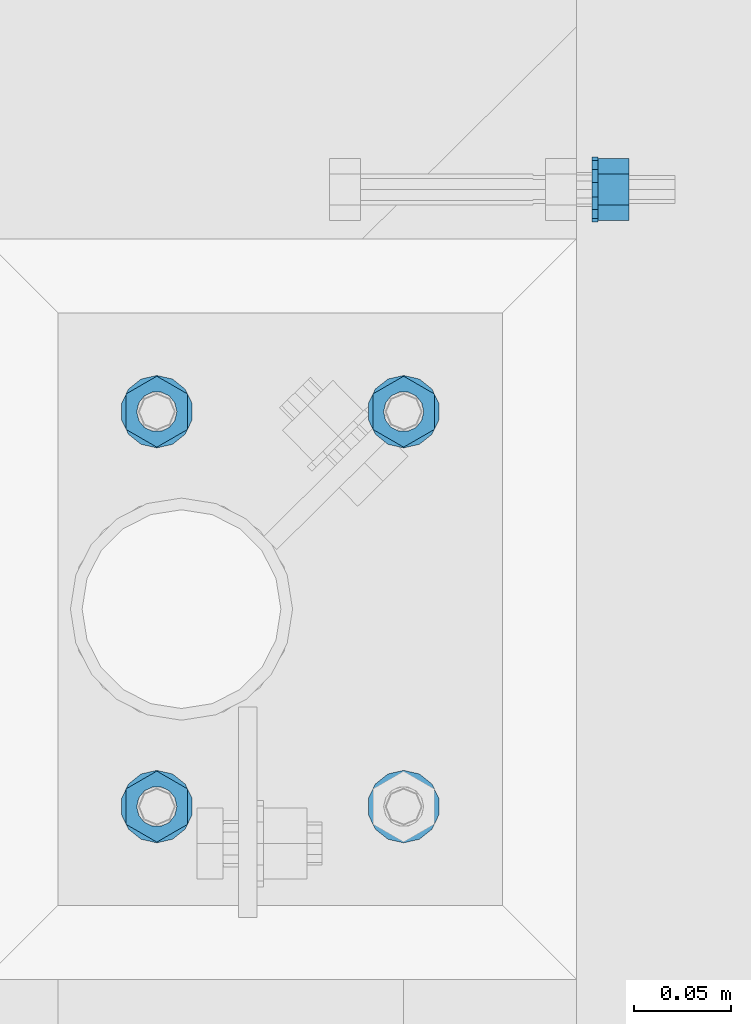
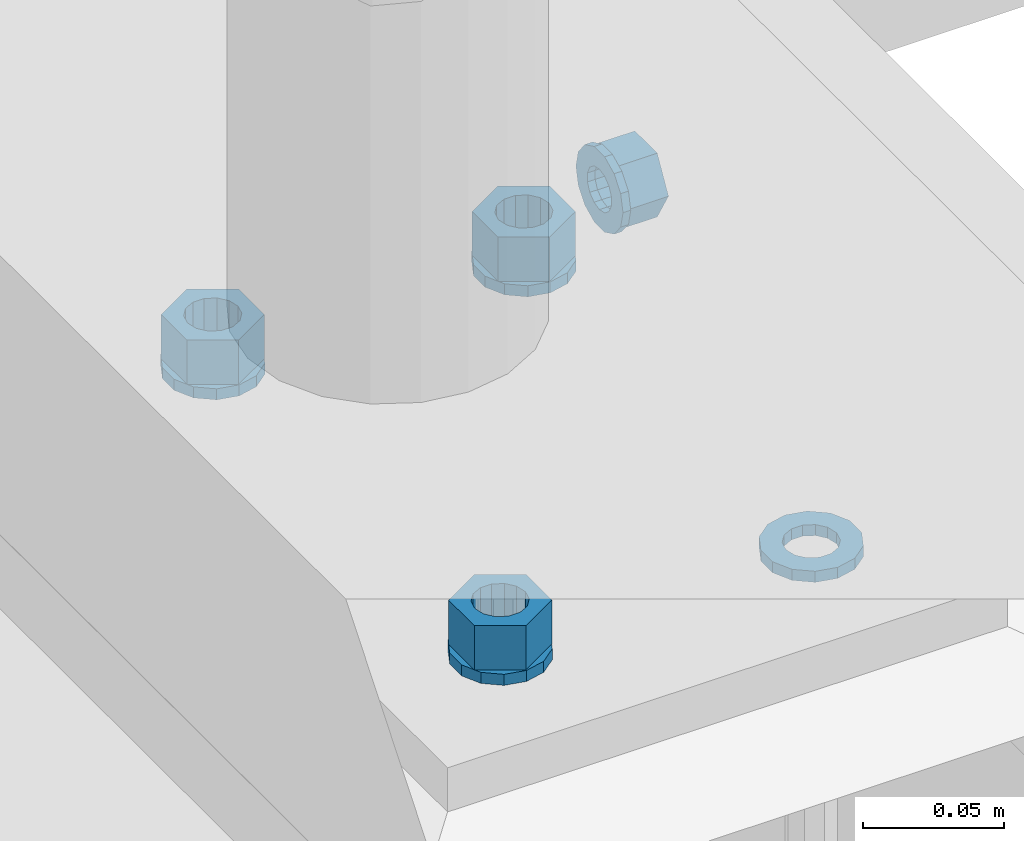
# One storey, part 589 of 975: 9 beams.
"""IFC2X3 building model written with IfcOpenShell, lengths in millimetres."""

from ifc_helpers import new_model, si_unit, frame, origin_with_axes, place, context, subcontext, project, spatial, faceted_brep, material, type_object, element, save


model = new_model("IFC2X3")

# Units and contexts
model_context = context("Model", 3, precision=1e-05, world=origin_with_axes())
body_context = subcontext(model_context, "Body", "Model", "MODEL_VIEW")
ifc_project = project(units=[si_unit("LENGTHUNIT", "METRE", prefix="MILLI"), si_unit("AREAUNIT", "SQUARE_METRE"), si_unit("VOLUMEUNIT", "CUBIC_METRE"), si_unit("MASSUNIT", "GRAM", prefix="KILO"), si_unit("TIMEUNIT", "SECOND"), si_unit("PLANEANGLEUNIT", "RADIAN"), si_unit("SOLIDANGLEUNIT", "STERADIAN"), si_unit("THERMODYNAMICTEMPERATUREUNIT", "DEGREE_CELSIUS"), si_unit("LUMINOUSINTENSITYUNIT", "LUMEN")], contexts=[model_context])

# Site, building, storey
site_placement = place(None, origin_with_axes())
site = spatial("IfcSite", under=ifc_project, at=site_placement, CompositionType="ELEMENT")
building_placement = place(site_placement, origin_with_axes())
building = spatial("IfcBuilding", under=site, at=building_placement, Name="Undefined", CompositionType="ELEMENT")
storey_placement = place(building_placement, origin_with_axes())
storey = spatial("IfcBuildingStorey", under=building, at=storey_placement, Name="Undefined", CompositionType="ELEMENT", Elevation=0.0)

# Beams
ifc_material = material(Name="STEEL/A36")
beam_type_1 = type_object("IfcBeamType", Name="5/8_HEAVY_HEX_NUT", PredefinedType="NOTDEFINED")
beam_1_placement = place(storey_placement, frame((2347.91263689955, 15614.6499761124, 3886.2), z_axis=(0.0, 0.0, -1.0), x_axis=(-0.999999999999998, 6.90000001668524e-08, 0.0)))
element("IfcBeam", 1, at=beam_1_placement, inside=storey, type_object=beam_type_1, material=ifc_material, Name="NUT", ObjectType="5/8_HEAVY_HEX_NUT", context=body_context, shape_type="Brep", body=[
    faceted_brep([(-1.09139364212751e-11, -15.8800001144436, -2.72848410531878e-12), (1.45519152283669e-11, -7.94000005722046, -13.7500000000036), (15.8750000000146, -7.94000005722137, -13.7500000000045), (15.8749999999891, -15.8800001144446, -2.72848410531878e-12), (2.91038304567337e-11, 7.94000005722319, -13.7500000000027), (15.8750000000291, 7.94000005722319, -13.7500000000027), (2.18278728425503e-11, 15.8800001144436, 9.09494701772928e-13), (15.8750000000218, 15.8800001144427, 9.09494701772928e-13), (-7.27595761418343e-12, 7.94000005722046, 13.7500000000027), (15.8749999999927, 7.94000005722046, 13.7500000000027), (-2.18278728425503e-11, -7.94000005722228, 13.7500000000009), (15.8749999999782, -7.94000005722319, 13.7500000000009), (-7.27595761418343e-12, 0.0, 8.72999954223724), (0.0, 3.78780484388062, 7.86545780435881), (15.875, 3.78780484387971, 7.86545780435881), (15.8749999999927, -9.09494701772928e-13, 8.72999954223724), (7.27595761418343e-12, 6.82538848405238, 5.44306568481716), (15.8750000000073, 6.82538848405238, 5.44306568481716), (1.09139364212751e-11, 8.51112022706275, 1.94260765157742), (15.8750000000109, 8.51112022706093, 1.94260765157651), (1.45519152283669e-11, 8.51112022706184, -1.94260765157651), (15.8750000000146, 8.51112022706184, -1.94260765157651), (2.18278728425503e-11, 6.8253884840542, -5.44306568481716), (15.8750000000218, 6.82538848405238, -5.44306568481716), (1.81898940354586e-11, 3.78780484388153, -7.86545780435881), (15.8750000000182, 3.78780484388062, -7.86545780435881), (1.81898940354586e-11, 9.09494701772928e-13, -8.72999954223997), (15.8750000000182, 9.09494701772928e-13, -8.72999954223997), (1.09139364212751e-11, -3.78780484387971, -7.86545780436063), (15.8750000000109, -3.78780484388062, -7.86545780436063), (3.63797880709171e-12, -6.82538848405238, -5.44306568481807), (15.8750000000036, -6.82538848405329, -5.44306568481807), (0.0, -8.51112022706184, -1.94260765157833), (15.875, -8.51112022706184, -1.94260765157833), (-7.27595761418343e-12, -8.51112022706184, 1.9426076515756), (15.8749999999927, -8.51112022706275, 1.9426076515756), (-1.09139364212751e-11, -6.82538848405329, 5.44306568481534), (15.8749999999927, -6.8253884840542, 5.44306568481534), (-7.27595761418343e-12, -3.78780484388062, 7.8654578043579), (15.8749999999927, -3.78780484388153, 7.8654578043579)], [[[0, 1, 2, 3]], [[1, 4, 5, 2]], [[4, 6, 7, 5]], [[6, 8, 9, 7]], [[8, 10, 11, 9]], [[10, 0, 3, 11]], [[12, 13, 14, 15]], [[13, 16, 17, 14]], [[16, 18, 19, 17]], [[18, 20, 21, 19]], [[20, 22, 23, 21]], [[22, 24, 25, 23]], [[24, 26, 27, 25]], [[26, 28, 29, 27]], [[28, 30, 31, 29]], [[30, 32, 33, 31]], [[32, 34, 35, 33]], [[34, 36, 37, 35]], [[36, 38, 39, 37]], [[38, 12, 15, 39]], [[5, 7, 9, 11, 3, 2], [17, 19, 21, 23, 25, 27, 29, 31, 33, 35, 37, 39, 15, 14]], [[10, 8, 6, 4, 1, 0], [38, 36, 34, 32, 30, 28, 26, 24, 22, 20, 18, 16, 13, 12]]]),
])
beam_type_2 = type_object("IfcBeamType", Name="5/8_WASHER", PredefinedType="NOTDEFINED")
beam_2_placement = place(storey_placement, frame((2332.03763689955, 15614.6499761124, 3886.2), z_axis=(0.0, 0.0, -1.0), x_axis=(-0.999999999999998, 6.90000001668524e-08, 0.0)))
element("IfcBeam", 2, at=beam_2_placement, inside=storey, type_object=beam_type_2, material=ifc_material, Name="WASHER", ObjectType="5/8_WASHER", context=body_context, shape_type="Brep", body=[
    faceted_brep([(1.09139364212751e-11, -16.670000076293, -2.72848410531878e-12), (2.18278728425503e-11, -15.0191510966704, -7.23284196419536), (3.1750000000211, -15.0191510966711, -7.23284196419627), (3.17500000001019, -16.6700000762937, -1.81898940354586e-12), (2.91038304567337e-11, -10.3935750445523, -13.0331308723944), (3.17500000002838, -10.3935750445526, -13.0331308723953), (2.91038304567337e-11, -3.70942398602756, -16.2520483704566), (3.17500000002838, -3.70942398602779, -16.2520483704566), (2.5465851649642e-11, 3.70942398602961, -16.2520483704557), (3.17500000002474, 3.70942398602961, -16.2520483704566), (1.45519152283669e-11, 10.3935750445542, -13.0331308723935), (3.17500000001382, 10.3935750445537, -13.0331308723944), (0.0, 15.0191510966717, -7.23284196419354), (3.17499999999927, 15.0191510966713, -7.23284196419354), (-7.27595761418343e-12, 16.6700000762933, 0.0), (3.174999999992, 16.6700000762928, -9.09494701772928e-13), (-1.81898940354586e-11, 15.0191510966706, 7.23284196419354), (3.17499999998108, 15.0191510966704, 7.23284196419354), (-2.5465851649642e-11, 10.3935750445519, 13.0331308723926), (3.17499999997381, 10.3935750445517, 13.0331308723926), (-2.5465851649642e-11, 3.70942398602733, 16.2520483704538), (3.17499999997381, 3.7094239860271, 16.2520483704529), (-2.18278728425503e-11, -3.70942398602983, 16.2520483704529), (3.17499999997744, -3.70942398603006, 16.2520483704538), (-1.09139364212751e-11, -10.3935750445542, 13.0331308723908), (3.17499999998836, -10.3935750445544, 13.0331308723908), (0.0, -15.0191510966717, 7.23284196419172), (3.17499999999927, -15.019151096672, 7.23284196419081), (-7.27595761418343e-12, 0.0, 8.72999954223724), (0.0, 3.78780484388062, 7.86545780435881), (3.17499999998472, 3.78780484387903, 7.86545780435699), (3.17499999998836, -9.09494701772928e-13, 8.72999954223542), (7.27595761418343e-12, 6.82538848405238, 5.44306568481716), (3.17499999998836, 6.82538848405102, 5.44306568481534), (1.09139364212751e-11, 8.51112022706275, 1.94260765157742), (3.174999999992, 8.51112022705979, 1.94260765157651), (1.45519152283669e-11, 8.51112022706184, -1.94260765157651), (3.17499999999563, 8.51112022706025, -1.94260765157742), (2.18278728425503e-11, 6.8253884840542, -5.44306568481716), (3.17500000000655, 6.8253884840517, -5.44306568481807), (1.81898940354586e-11, 3.78780484388153, -7.86545780435881), (3.17500000001019, 3.78780484388017, -7.86545780435972), (1.81898940354586e-11, 9.09494701772928e-13, -8.72999954223997), (3.17500000001382, 6.82121026329696e-13, -8.72999954223997), (1.09139364212751e-11, -3.78780484387971, -7.86545780436063), (3.17500000001382, -3.78780484387994, -7.86545780436063), (3.63797880709171e-12, -6.82538848405238, -5.44306568481807), (3.17500000001019, -6.82538848405147, -5.44306568481898), (0.0, -8.51112022706184, -1.94260765157833), (3.17500000001019, -8.5111202270607, -1.94260765157924), (-7.27595761418343e-12, -8.51112022706184, 1.9426076515756), (3.17500000000291, -8.51112022706093, 1.94260765157469), (-1.09139364212751e-11, -6.82538848405329, 5.44306568481534), (3.17499999999563, -6.82538848405238, 5.44306568481534), (-7.27595761418343e-12, -3.78780484388062, 7.8654578043579), (3.174999999992, -3.78780484388085, 7.86545780435699)], [[[0, 1, 2, 3]], [[1, 4, 5, 2]], [[4, 6, 7, 5]], [[6, 8, 9, 7]], [[8, 10, 11, 9]], [[10, 12, 13, 11]], [[12, 14, 15, 13]], [[14, 16, 17, 15]], [[16, 18, 19, 17]], [[18, 20, 21, 19]], [[20, 22, 23, 21]], [[22, 24, 25, 23]], [[24, 26, 27, 25]], [[26, 0, 3, 27]], [[28, 29, 30, 31]], [[29, 32, 33, 30]], [[32, 34, 35, 33]], [[34, 36, 37, 35]], [[36, 38, 39, 37]], [[38, 40, 41, 39]], [[40, 42, 43, 41]], [[42, 44, 45, 43]], [[44, 46, 47, 45]], [[46, 48, 49, 47]], [[48, 50, 51, 49]], [[50, 52, 53, 51]], [[52, 54, 55, 53]], [[54, 28, 31, 55]], [[5, 7, 9, 11, 13, 15, 17, 19, 21, 23, 25, 27, 3, 2], [33, 35, 37, 39, 41, 43, 45, 47, 49, 51, 53, 55, 31, 30]], [[26, 24, 22, 20, 18, 16, 14, 12, 10, 8, 6, 4, 1, 0], [54, 52, 50, 48, 46, 44, 42, 40, 38, 36, 34, 32, 29, 28]]]),
])
beam_type_3 = type_object("IfcBeamType", Name="3/4_WASHER", PredefinedType="NOTDEFINED")
beam_3_placement = place(storey_placement, frame((2105.02500137409, 15500.3500011752, 3960.8125), z_axis=(1.0, 0.0, 0.0), x_axis=(0.0, 0.0, -1.0)))
element("IfcBeam", 3, at=beam_3_placement, inside=storey, type_object=beam_type_3, material=ifc_material, Name="WASHER", ObjectType="3/4_WASHER", context=body_context, shape_type="Brep", body=[
    faceted_brep([(0.0, -18.6499996185303, 0.0), (0.0, -16.8030690426876, -8.09193156902904), (4.76250000000073, -16.8030690426876, -8.09193156902904), (4.76250000000073, -18.6499996185303, 0.0), (0.0, -11.6280845668225, -14.5811568497838), (4.76250000000073, -11.6280845668225, -14.5811568497838), (0.0, -4.15001533340001, -18.1824051902857), (4.76250000000073, -4.15001533340001, -18.1824051902857), (0.0, 4.15001533340001, -18.1824051902857), (4.76250000000073, 4.15001533340001, -18.1824051902857), (0.0, 11.6280845668234, -14.5811568497838), (4.76250000000073, 11.6280845668234, -14.5811568497838), (0.0, 16.8030690426876, -8.09193156902904), (4.76250000000073, 16.8030690426876, -8.09193156902904), (0.0, 18.6499996185303, 0.0), (4.76250000000073, 18.6499996185303, 0.0), (0.0, 16.8030690426876, 8.09193156902904), (4.76250000000073, 16.8030690426876, 8.09193156902904), (0.0, 11.6280845668225, 14.5811568497838), (4.76250000000073, 11.6280845668225, 14.5811568497838), (0.0, 4.15001533340001, 18.1824051902857), (4.76250000000073, 4.15001533340001, 18.1824051902857), (0.0, -4.15001533340001, 18.1824051902857), (4.76250000000073, -4.15001533340001, 18.1824051902857), (0.0, -11.6280845668234, 14.5811568497838), (4.76250000000073, -11.6280845668234, 14.5811568497838), (0.0, -16.8030690426876, 8.09193156902904), (4.76250000000073, -16.8030690426876, 8.09193156902904), (0.0, 0.0, 10.3199996948242), (0.0, 4.47768005528269, 9.29799844179911), (4.76250000000073, 4.47768005528269, 9.29799844179911), (4.76250000000073, 0.0, 10.3199996948242), (0.0, 8.06850066047446, 6.43441456490817), (4.76250000000073, 8.06850066047446, 6.43441456490817), (0.0, 10.0612557561917, 2.29641597052117), (4.76250000000073, 10.0612557561917, 2.29641597052117), (0.0, 10.0612557561917, -2.29641597052117), (4.76250000000073, 10.0612557561917, -2.29641597052117), (0.0, 8.06850066047446, -6.43441456490814), (4.76250000000073, 8.06850066047446, -6.43441456490814), (0.0, 4.47768005528269, -9.29799844179908), (4.76250000000073, 4.47768005528269, -9.29799844179908), (0.0, 0.0, -10.3199996948242), (4.76250000000073, 0.0, -10.3199996948242), (0.0, -4.47768005528269, -9.29799844179911), (4.76250000000073, -4.47768005528269, -9.29799844179911), (0.0, -8.06850066047446, -6.43441456490817), (4.76250000000073, -8.06850066047446, -6.43441456490817), (0.0, -10.0612557561917, -2.29641597052117), (4.76250000000073, -10.0612557561917, -2.29641597052117), (0.0, -10.0612557561917, 2.29641597052117), (4.76250000000073, -10.0612557561917, 2.29641597052117), (0.0, -8.06850066047446, 6.43441456490814), (4.76250000000073, -8.06850066047446, 6.43441456490814), (0.0, -4.47768005528269, 9.29799844179908), (4.76250000000073, -4.47768005528269, 9.29799844179908)], [[[0, 1, 2, 3]], [[1, 4, 5, 2]], [[4, 6, 7, 5]], [[6, 8, 9, 7]], [[8, 10, 11, 9]], [[10, 12, 13, 11]], [[12, 14, 15, 13]], [[14, 16, 17, 15]], [[16, 18, 19, 17]], [[18, 20, 21, 19]], [[20, 22, 23, 21]], [[22, 24, 25, 23]], [[24, 26, 27, 25]], [[26, 0, 3, 27]], [[28, 29, 30, 31]], [[29, 32, 33, 30]], [[32, 34, 35, 33]], [[34, 36, 37, 35]], [[36, 38, 39, 37]], [[38, 40, 41, 39]], [[40, 42, 43, 41]], [[42, 44, 45, 43]], [[44, 46, 47, 45]], [[46, 48, 49, 47]], [[48, 50, 51, 49]], [[50, 52, 53, 51]], [[52, 54, 55, 53]], [[54, 28, 31, 55]], [[5, 7, 9, 11, 13, 15, 17, 19, 21, 23, 25, 27, 3, 2], [33, 35, 37, 39, 41, 43, 45, 47, 49, 51, 53, 55, 31, 30]], [[26, 24, 22, 20, 18, 16, 14, 12, 10, 8, 6, 4, 1, 0], [54, 52, 50, 48, 46, 44, 42, 40, 38, 36, 34, 32, 29, 28]]]),
])
beam_4_placement = place(storey_placement, frame((2105.02500137409, 15297.1500011752, 3960.8125), z_axis=(1.0, 0.0, 0.0), x_axis=(0.0, 0.0, -1.0)))
element("IfcBeam", 4, at=beam_4_placement, inside=storey, type_object=beam_type_3, material=ifc_material, Name="WASHER", ObjectType="3/4_WASHER", context=body_context, shape_type="Brep", body=[
    faceted_brep([(0.0, -18.6499996185303, 0.0), (0.0, -16.8030690426876, -8.09193156902904), (4.76250000000073, -16.8030690426876, -8.09193156902904), (4.76250000000073, -18.6499996185303, 0.0), (0.0, -11.6280845668225, -14.5811568497838), (4.76250000000073, -11.6280845668225, -14.5811568497838), (0.0, -4.15001533340001, -18.1824051902857), (4.76250000000073, -4.15001533340001, -18.1824051902857), (0.0, 4.15001533340001, -18.1824051902857), (4.76250000000073, 4.15001533340001, -18.1824051902857), (0.0, 11.6280845668234, -14.5811568497838), (4.76250000000073, 11.6280845668234, -14.5811568497838), (0.0, 16.8030690426876, -8.09193156902904), (4.76250000000073, 16.8030690426876, -8.09193156902904), (0.0, 18.6499996185303, 0.0), (4.76250000000073, 18.6499996185303, 0.0), (0.0, 16.8030690426876, 8.09193156902904), (4.76250000000073, 16.8030690426876, 8.09193156902904), (0.0, 11.6280845668225, 14.5811568497838), (4.76250000000073, 11.6280845668225, 14.5811568497838), (0.0, 4.15001533340001, 18.1824051902857), (4.76250000000073, 4.15001533340001, 18.1824051902857), (0.0, -4.15001533340001, 18.1824051902857), (4.76250000000073, -4.15001533340001, 18.1824051902857), (0.0, -11.6280845668234, 14.5811568497838), (4.76250000000073, -11.6280845668234, 14.5811568497838), (0.0, -16.8030690426876, 8.09193156902904), (4.76250000000073, -16.8030690426876, 8.09193156902904), (0.0, 0.0, 10.3199996948242), (0.0, 4.47768005528269, 9.29799844179911), (4.76250000000073, 4.47768005528269, 9.29799844179911), (4.76250000000073, 0.0, 10.3199996948242), (0.0, 8.06850066047446, 6.43441456490817), (4.76250000000073, 8.06850066047446, 6.43441456490817), (0.0, 10.0612557561917, 2.29641597052117), (4.76250000000073, 10.0612557561917, 2.29641597052117), (0.0, 10.0612557561917, -2.29641597052117), (4.76250000000073, 10.0612557561917, -2.29641597052117), (0.0, 8.06850066047446, -6.43441456490814), (4.76250000000073, 8.06850066047446, -6.43441456490814), (0.0, 4.47768005528269, -9.29799844179908), (4.76250000000073, 4.47768005528269, -9.29799844179908), (0.0, 0.0, -10.3199996948242), (4.76250000000073, 0.0, -10.3199996948242), (0.0, -4.47768005528269, -9.29799844179911), (4.76250000000073, -4.47768005528269, -9.29799844179911), (0.0, -8.06850066047446, -6.43441456490817), (4.76250000000073, -8.06850066047446, -6.43441456490817), (0.0, -10.0612557561917, -2.29641597052117), (4.76250000000073, -10.0612557561917, -2.29641597052117), (0.0, -10.0612557561917, 2.29641597052117), (4.76250000000073, -10.0612557561917, 2.29641597052117), (0.0, -8.06850066047446, 6.43441456490814), (4.76250000000073, -8.06850066047446, 6.43441456490814), (0.0, -4.47768005528269, 9.29799844179908), (4.76250000000073, -4.47768005528269, 9.29799844179908)], [[[0, 1, 2, 3]], [[1, 4, 5, 2]], [[4, 6, 7, 5]], [[6, 8, 9, 7]], [[8, 10, 11, 9]], [[10, 12, 13, 11]], [[12, 14, 15, 13]], [[14, 16, 17, 15]], [[16, 18, 19, 17]], [[18, 20, 21, 19]], [[20, 22, 23, 21]], [[22, 24, 25, 23]], [[24, 26, 27, 25]], [[26, 0, 3, 27]], [[28, 29, 30, 31]], [[29, 32, 33, 30]], [[32, 34, 35, 33]], [[34, 36, 37, 35]], [[36, 38, 39, 37]], [[38, 40, 41, 39]], [[40, 42, 43, 41]], [[42, 44, 45, 43]], [[44, 46, 47, 45]], [[46, 48, 49, 47]], [[48, 50, 51, 49]], [[50, 52, 53, 51]], [[52, 54, 55, 53]], [[54, 28, 31, 55]], [[5, 7, 9, 11, 13, 15, 17, 19, 21, 23, 25, 27, 3, 2], [33, 35, 37, 39, 41, 43, 45, 47, 49, 51, 53, 55, 31, 30]], [[26, 24, 22, 20, 18, 16, 14, 12, 10, 8, 6, 4, 1, 0], [54, 52, 50, 48, 46, 44, 42, 40, 38, 36, 34, 32, 29, 28]]]),
])
beam_5_placement = place(storey_placement, frame((2232.02500137409, 15500.3500011752, 3960.8125), z_axis=(1.0, 0.0, 0.0), x_axis=(0.0, 0.0, -1.0)))
element("IfcBeam", 5, at=beam_5_placement, inside=storey, type_object=beam_type_3, material=ifc_material, Name="WASHER", ObjectType="3/4_WASHER", context=body_context, shape_type="Brep", body=[
    faceted_brep([(0.0, -18.6499996185303, 0.0), (0.0, -16.8030690426876, -8.09193156902904), (4.76250000000073, -16.8030690426876, -8.09193156902904), (4.76250000000073, -18.6499996185303, 0.0), (0.0, -11.6280845668225, -14.5811568497838), (4.76250000000073, -11.6280845668225, -14.5811568497838), (0.0, -4.15001533340001, -18.1824051902857), (4.76250000000073, -4.15001533340001, -18.1824051902857), (0.0, 4.15001533340001, -18.1824051902857), (4.76250000000073, 4.15001533340001, -18.1824051902857), (0.0, 11.6280845668234, -14.5811568497838), (4.76250000000073, 11.6280845668234, -14.5811568497838), (0.0, 16.8030690426876, -8.09193156902904), (4.76250000000073, 16.8030690426876, -8.09193156902904), (0.0, 18.6499996185303, 0.0), (4.76250000000073, 18.6499996185303, 0.0), (0.0, 16.8030690426876, 8.09193156902904), (4.76250000000073, 16.8030690426876, 8.09193156902904), (0.0, 11.6280845668225, 14.5811568497838), (4.76250000000073, 11.6280845668225, 14.5811568497838), (0.0, 4.15001533340001, 18.1824051902857), (4.76250000000073, 4.15001533340001, 18.1824051902857), (0.0, -4.15001533340001, 18.1824051902857), (4.76250000000073, -4.15001533340001, 18.1824051902857), (0.0, -11.6280845668234, 14.5811568497838), (4.76250000000073, -11.6280845668234, 14.5811568497838), (0.0, -16.8030690426876, 8.09193156902904), (4.76250000000073, -16.8030690426876, 8.09193156902904), (0.0, 0.0, 10.3199996948242), (0.0, 4.47768005528269, 9.29799844179911), (4.76250000000073, 4.47768005528269, 9.29799844179911), (4.76250000000073, 0.0, 10.3199996948242), (0.0, 8.06850066047446, 6.43441456490817), (4.76250000000073, 8.06850066047446, 6.43441456490817), (0.0, 10.0612557561917, 2.29641597052117), (4.76250000000073, 10.0612557561917, 2.29641597052117), (0.0, 10.0612557561917, -2.29641597052117), (4.76250000000073, 10.0612557561917, -2.29641597052117), (0.0, 8.06850066047446, -6.43441456490814), (4.76250000000073, 8.06850066047446, -6.43441456490814), (0.0, 4.47768005528269, -9.29799844179908), (4.76250000000073, 4.47768005528269, -9.29799844179908), (0.0, 0.0, -10.3199996948242), (4.76250000000073, 0.0, -10.3199996948242), (0.0, -4.47768005528269, -9.29799844179911), (4.76250000000073, -4.47768005528269, -9.29799844179911), (0.0, -8.06850066047446, -6.43441456490817), (4.76250000000073, -8.06850066047446, -6.43441456490817), (0.0, -10.0612557561917, -2.29641597052117), (4.76250000000073, -10.0612557561917, -2.29641597052117), (0.0, -10.0612557561917, 2.29641597052117), (4.76250000000073, -10.0612557561917, 2.29641597052117), (0.0, -8.06850066047446, 6.43441456490814), (4.76250000000073, -8.06850066047446, 6.43441456490814), (0.0, -4.47768005528269, 9.29799844179908), (4.76250000000073, -4.47768005528269, 9.29799844179908)], [[[0, 1, 2, 3]], [[1, 4, 5, 2]], [[4, 6, 7, 5]], [[6, 8, 9, 7]], [[8, 10, 11, 9]], [[10, 12, 13, 11]], [[12, 14, 15, 13]], [[14, 16, 17, 15]], [[16, 18, 19, 17]], [[18, 20, 21, 19]], [[20, 22, 23, 21]], [[22, 24, 25, 23]], [[24, 26, 27, 25]], [[26, 0, 3, 27]], [[28, 29, 30, 31]], [[29, 32, 33, 30]], [[32, 34, 35, 33]], [[34, 36, 37, 35]], [[36, 38, 39, 37]], [[38, 40, 41, 39]], [[40, 42, 43, 41]], [[42, 44, 45, 43]], [[44, 46, 47, 45]], [[46, 48, 49, 47]], [[48, 50, 51, 49]], [[50, 52, 53, 51]], [[52, 54, 55, 53]], [[54, 28, 31, 55]], [[5, 7, 9, 11, 13, 15, 17, 19, 21, 23, 25, 27, 3, 2], [33, 35, 37, 39, 41, 43, 45, 47, 49, 51, 53, 55, 31, 30]], [[26, 24, 22, 20, 18, 16, 14, 12, 10, 8, 6, 4, 1, 0], [54, 52, 50, 48, 46, 44, 42, 40, 38, 36, 34, 32, 29, 28]]]),
])
beam_6_placement = place(storey_placement, frame((2232.02500137409, 15297.1500011752, 3960.8125), z_axis=(1.0, 0.0, 0.0), x_axis=(0.0, 0.0, -1.0)))
element("IfcBeam", 6, at=beam_6_placement, inside=storey, type_object=beam_type_3, material=ifc_material, Name="WASHER", ObjectType="3/4_WASHER", context=body_context, shape_type="Brep", body=[
    faceted_brep([(0.0, -18.6499996185303, 0.0), (0.0, -16.8030690426876, -8.09193156902904), (4.76250000000073, -16.8030690426876, -8.09193156902904), (4.76250000000073, -18.6499996185303, 0.0), (0.0, -11.6280845668225, -14.5811568497838), (4.76250000000073, -11.6280845668225, -14.5811568497838), (0.0, -4.15001533340001, -18.1824051902857), (4.76250000000073, -4.15001533340001, -18.1824051902857), (0.0, 4.15001533340001, -18.1824051902857), (4.76250000000073, 4.15001533340001, -18.1824051902857), (0.0, 11.6280845668234, -14.5811568497838), (4.76250000000073, 11.6280845668234, -14.5811568497838), (0.0, 16.8030690426876, -8.09193156902904), (4.76250000000073, 16.8030690426876, -8.09193156902904), (0.0, 18.6499996185303, 0.0), (4.76250000000073, 18.6499996185303, 0.0), (0.0, 16.8030690426876, 8.09193156902904), (4.76250000000073, 16.8030690426876, 8.09193156902904), (0.0, 11.6280845668225, 14.5811568497838), (4.76250000000073, 11.6280845668225, 14.5811568497838), (0.0, 4.15001533340001, 18.1824051902857), (4.76250000000073, 4.15001533340001, 18.1824051902857), (0.0, -4.15001533340001, 18.1824051902857), (4.76250000000073, -4.15001533340001, 18.1824051902857), (0.0, -11.6280845668234, 14.5811568497838), (4.76250000000073, -11.6280845668234, 14.5811568497838), (0.0, -16.8030690426876, 8.09193156902904), (4.76250000000073, -16.8030690426876, 8.09193156902904), (0.0, 0.0, 10.3199996948242), (0.0, 4.47768005528269, 9.29799844179911), (4.76250000000073, 4.47768005528269, 9.29799844179911), (4.76250000000073, 0.0, 10.3199996948242), (0.0, 8.06850066047446, 6.43441456490817), (4.76250000000073, 8.06850066047446, 6.43441456490817), (0.0, 10.0612557561917, 2.29641597052117), (4.76250000000073, 10.0612557561917, 2.29641597052117), (0.0, 10.0612557561917, -2.29641597052117), (4.76250000000073, 10.0612557561917, -2.29641597052117), (0.0, 8.06850066047446, -6.43441456490814), (4.76250000000073, 8.06850066047446, -6.43441456490814), (0.0, 4.47768005528269, -9.29799844179908), (4.76250000000073, 4.47768005528269, -9.29799844179908), (0.0, 0.0, -10.3199996948242), (4.76250000000073, 0.0, -10.3199996948242), (0.0, -4.47768005528269, -9.29799844179911), (4.76250000000073, -4.47768005528269, -9.29799844179911), (0.0, -8.06850066047446, -6.43441456490817), (4.76250000000073, -8.06850066047446, -6.43441456490817), (0.0, -10.0612557561917, -2.29641597052117), (4.76250000000073, -10.0612557561917, -2.29641597052117), (0.0, -10.0612557561917, 2.29641597052117), (4.76250000000073, -10.0612557561917, 2.29641597052117), (0.0, -8.06850066047446, 6.43441456490814), (4.76250000000073, -8.06850066047446, 6.43441456490814), (0.0, -4.47768005528269, 9.29799844179908), (4.76250000000073, -4.47768005528269, 9.29799844179908)], [[[0, 1, 2, 3]], [[1, 4, 5, 2]], [[4, 6, 7, 5]], [[6, 8, 9, 7]], [[8, 10, 11, 9]], [[10, 12, 13, 11]], [[12, 14, 15, 13]], [[14, 16, 17, 15]], [[16, 18, 19, 17]], [[18, 20, 21, 19]], [[20, 22, 23, 21]], [[22, 24, 25, 23]], [[24, 26, 27, 25]], [[26, 0, 3, 27]], [[28, 29, 30, 31]], [[29, 32, 33, 30]], [[32, 34, 35, 33]], [[34, 36, 37, 35]], [[36, 38, 39, 37]], [[38, 40, 41, 39]], [[40, 42, 43, 41]], [[42, 44, 45, 43]], [[44, 46, 47, 45]], [[46, 48, 49, 47]], [[48, 50, 51, 49]], [[50, 52, 53, 51]], [[52, 54, 55, 53]], [[54, 28, 31, 55]], [[5, 7, 9, 11, 13, 15, 17, 19, 21, 23, 25, 27, 3, 2], [33, 35, 37, 39, 41, 43, 45, 47, 49, 51, 53, 55, 31, 30]], [[26, 24, 22, 20, 18, 16, 14, 12, 10, 8, 6, 4, 1, 0], [54, 52, 50, 48, 46, 44, 42, 40, 38, 36, 34, 32, 29, 28]]]),
])
beam_type_4 = type_object("IfcBeamType", Name="3/4_HEAVY_HEX_NUT", PredefinedType="NOTDEFINED")
beam_7_placement = place(storey_placement, frame((2105.02500137409, 15500.3500011752, 3979.8625), z_axis=(1.0, 0.0, 0.0), x_axis=(0.0, 0.0, -1.0)))
element("IfcBeam", 7, at=beam_7_placement, inside=storey, type_object=beam_type_4, material=ifc_material, Name="NUT", ObjectType="3/4_HEAVY_HEX_NUT", context=body_context, shape_type="Brep", body=[
    faceted_brep([(0.0, -18.2600002288818, 0.0), (0.0, -9.13000011444092, -15.8100004196167), (19.0499999999993, -9.13000011444092, -15.8100004196167), (19.0499999999993, -18.2600002288818, 0.0), (0.0, 9.13000011444092, -15.8100004196167), (19.0499999999993, 9.13000011444092, -15.8100004196167), (0.0, 18.2600002288818, 0.0), (19.0499999999993, 18.2600002288818, 0.0), (0.0, 9.13000011444092, 15.8100004196167), (19.0499999999993, 9.13000011444092, 15.8100004196167), (0.0, -9.13000011444092, 15.8100004196167), (19.0499999999993, -9.13000011444092, 15.8100004196167), (0.0, 0.0, 10.3199996948242), (0.0, 4.47768005528269, 9.29799844179911), (19.0499999999993, 4.47768005528269, 9.29799844179911), (19.0499999999993, 0.0, 10.3199996948242), (0.0, 8.06850066047446, 6.43441456490817), (19.0499999999993, 8.06850066047446, 6.43441456490817), (0.0, 10.0612557561917, 2.29641597052117), (19.0499999999993, 10.0612557561917, 2.29641597052117), (0.0, 10.0612557561917, -2.29641597052117), (19.0499999999993, 10.0612557561917, -2.29641597052117), (0.0, 8.06850066047446, -6.43441456490814), (19.0499999999993, 8.06850066047446, -6.43441456490814), (0.0, 4.47768005528269, -9.29799844179908), (19.0499999999993, 4.47768005528269, -9.29799844179908), (0.0, 0.0, -10.3199996948242), (19.0499999999993, 0.0, -10.3199996948242), (0.0, -4.47768005528269, -9.29799844179911), (19.0499999999993, -4.47768005528269, -9.29799844179911), (0.0, -8.06850066047446, -6.43441456490817), (19.0499999999993, -8.06850066047446, -6.43441456490817), (0.0, -10.0612557561917, -2.29641597052117), (19.0499999999993, -10.0612557561917, -2.29641597052117), (0.0, -10.0612557561917, 2.29641597052117), (19.0499999999993, -10.0612557561917, 2.29641597052117), (0.0, -8.06850066047446, 6.43441456490814), (19.0499999999993, -8.06850066047446, 6.43441456490814), (0.0, -4.47768005528269, 9.29799844179908), (19.0499999999993, -4.47768005528269, 9.29799844179908)], [[[0, 1, 2, 3]], [[1, 4, 5, 2]], [[4, 6, 7, 5]], [[6, 8, 9, 7]], [[8, 10, 11, 9]], [[10, 0, 3, 11]], [[12, 13, 14, 15]], [[13, 16, 17, 14]], [[16, 18, 19, 17]], [[18, 20, 21, 19]], [[20, 22, 23, 21]], [[22, 24, 25, 23]], [[24, 26, 27, 25]], [[26, 28, 29, 27]], [[28, 30, 31, 29]], [[30, 32, 33, 31]], [[32, 34, 35, 33]], [[34, 36, 37, 35]], [[36, 38, 39, 37]], [[38, 12, 15, 39]], [[5, 7, 9, 11, 3, 2], [17, 19, 21, 23, 25, 27, 29, 31, 33, 35, 37, 39, 15, 14]], [[10, 8, 6, 4, 1, 0], [38, 36, 34, 32, 30, 28, 26, 24, 22, 20, 18, 16, 13, 12]]]),
])
beam_8_placement = place(storey_placement, frame((2105.02500137409, 15297.1500011752, 3979.8625), z_axis=(1.0, 0.0, 0.0), x_axis=(0.0, 0.0, -1.0)))
element("IfcBeam", 8, at=beam_8_placement, inside=storey, type_object=beam_type_4, material=ifc_material, Name="NUT", ObjectType="3/4_HEAVY_HEX_NUT", context=body_context, shape_type="Brep", body=[
    faceted_brep([(0.0, -18.2600002288818, 0.0), (0.0, -9.13000011444092, -15.8100004196167), (19.0499999999993, -9.13000011444092, -15.8100004196167), (19.0499999999993, -18.2600002288818, 0.0), (0.0, 9.13000011444092, -15.8100004196167), (19.0499999999993, 9.13000011444092, -15.8100004196167), (0.0, 18.2600002288818, 0.0), (19.0499999999993, 18.2600002288818, 0.0), (0.0, 9.13000011444092, 15.8100004196167), (19.0499999999993, 9.13000011444092, 15.8100004196167), (0.0, -9.13000011444092, 15.8100004196167), (19.0499999999993, -9.13000011444092, 15.8100004196167), (0.0, 0.0, 10.3199996948242), (0.0, 4.47768005528269, 9.29799844179911), (19.0499999999993, 4.47768005528269, 9.29799844179911), (19.0499999999993, 0.0, 10.3199996948242), (0.0, 8.06850066047446, 6.43441456490817), (19.0499999999993, 8.06850066047446, 6.43441456490817), (0.0, 10.0612557561917, 2.29641597052117), (19.0499999999993, 10.0612557561917, 2.29641597052117), (0.0, 10.0612557561917, -2.29641597052117), (19.0499999999993, 10.0612557561917, -2.29641597052117), (0.0, 8.06850066047446, -6.43441456490814), (19.0499999999993, 8.06850066047446, -6.43441456490814), (0.0, 4.47768005528269, -9.29799844179908), (19.0499999999993, 4.47768005528269, -9.29799844179908), (0.0, 0.0, -10.3199996948242), (19.0499999999993, 0.0, -10.3199996948242), (0.0, -4.47768005528269, -9.29799844179911), (19.0499999999993, -4.47768005528269, -9.29799844179911), (0.0, -8.06850066047446, -6.43441456490817), (19.0499999999993, -8.06850066047446, -6.43441456490817), (0.0, -10.0612557561917, -2.29641597052117), (19.0499999999993, -10.0612557561917, -2.29641597052117), (0.0, -10.0612557561917, 2.29641597052117), (19.0499999999993, -10.0612557561917, 2.29641597052117), (0.0, -8.06850066047446, 6.43441456490814), (19.0499999999993, -8.06850066047446, 6.43441456490814), (0.0, -4.47768005528269, 9.29799844179908), (19.0499999999993, -4.47768005528269, 9.29799844179908)], [[[0, 1, 2, 3]], [[1, 4, 5, 2]], [[4, 6, 7, 5]], [[6, 8, 9, 7]], [[8, 10, 11, 9]], [[10, 0, 3, 11]], [[12, 13, 14, 15]], [[13, 16, 17, 14]], [[16, 18, 19, 17]], [[18, 20, 21, 19]], [[20, 22, 23, 21]], [[22, 24, 25, 23]], [[24, 26, 27, 25]], [[26, 28, 29, 27]], [[28, 30, 31, 29]], [[30, 32, 33, 31]], [[32, 34, 35, 33]], [[34, 36, 37, 35]], [[36, 38, 39, 37]], [[38, 12, 15, 39]], [[5, 7, 9, 11, 3, 2], [17, 19, 21, 23, 25, 27, 29, 31, 33, 35, 37, 39, 15, 14]], [[10, 8, 6, 4, 1, 0], [38, 36, 34, 32, 30, 28, 26, 24, 22, 20, 18, 16, 13, 12]]]),
])
beam_9_placement = place(storey_placement, frame((2232.02500137409, 15500.3500011752, 3979.8625), z_axis=(1.0, 0.0, 0.0), x_axis=(0.0, 0.0, -1.0)))
element("IfcBeam", 9, at=beam_9_placement, inside=storey, type_object=beam_type_4, material=ifc_material, Name="NUT", ObjectType="3/4_HEAVY_HEX_NUT", context=body_context, shape_type="Brep", body=[
    faceted_brep([(0.0, -18.2600002288818, 0.0), (0.0, -9.13000011444092, -15.8100004196167), (19.0499999999993, -9.13000011444092, -15.8100004196167), (19.0499999999993, -18.2600002288818, 0.0), (0.0, 9.13000011444092, -15.8100004196167), (19.0499999999993, 9.13000011444092, -15.8100004196167), (0.0, 18.2600002288818, 0.0), (19.0499999999993, 18.2600002288818, 0.0), (0.0, 9.13000011444092, 15.8100004196167), (19.0499999999993, 9.13000011444092, 15.8100004196167), (0.0, -9.13000011444092, 15.8100004196167), (19.0499999999993, -9.13000011444092, 15.8100004196167), (0.0, 0.0, 10.3199996948242), (0.0, 4.47768005528269, 9.29799844179911), (19.0499999999993, 4.47768005528269, 9.29799844179911), (19.0499999999993, 0.0, 10.3199996948242), (0.0, 8.06850066047446, 6.43441456490817), (19.0499999999993, 8.06850066047446, 6.43441456490817), (0.0, 10.0612557561917, 2.29641597052117), (19.0499999999993, 10.0612557561917, 2.29641597052117), (0.0, 10.0612557561917, -2.29641597052117), (19.0499999999993, 10.0612557561917, -2.29641597052117), (0.0, 8.06850066047446, -6.43441456490814), (19.0499999999993, 8.06850066047446, -6.43441456490814), (0.0, 4.47768005528269, -9.29799844179908), (19.0499999999993, 4.47768005528269, -9.29799844179908), (0.0, 0.0, -10.3199996948242), (19.0499999999993, 0.0, -10.3199996948242), (0.0, -4.47768005528269, -9.29799844179911), (19.0499999999993, -4.47768005528269, -9.29799844179911), (0.0, -8.06850066047446, -6.43441456490817), (19.0499999999993, -8.06850066047446, -6.43441456490817), (0.0, -10.0612557561917, -2.29641597052117), (19.0499999999993, -10.0612557561917, -2.29641597052117), (0.0, -10.0612557561917, 2.29641597052117), (19.0499999999993, -10.0612557561917, 2.29641597052117), (0.0, -8.06850066047446, 6.43441456490814), (19.0499999999993, -8.06850066047446, 6.43441456490814), (0.0, -4.47768005528269, 9.29799844179908), (19.0499999999993, -4.47768005528269, 9.29799844179908)], [[[0, 1, 2, 3]], [[1, 4, 5, 2]], [[4, 6, 7, 5]], [[6, 8, 9, 7]], [[8, 10, 11, 9]], [[10, 0, 3, 11]], [[12, 13, 14, 15]], [[13, 16, 17, 14]], [[16, 18, 19, 17]], [[18, 20, 21, 19]], [[20, 22, 23, 21]], [[22, 24, 25, 23]], [[24, 26, 27, 25]], [[26, 28, 29, 27]], [[28, 30, 31, 29]], [[30, 32, 33, 31]], [[32, 34, 35, 33]], [[34, 36, 37, 35]], [[36, 38, 39, 37]], [[38, 12, 15, 39]], [[5, 7, 9, 11, 3, 2], [17, 19, 21, 23, 25, 27, 29, 31, 33, 35, 37, 39, 15, 14]], [[10, 8, 6, 4, 1, 0], [38, 36, 34, 32, 30, 28, 26, 24, 22, 20, 18, 16, 13, 12]]]),
])

save(model, "model.ifc")
